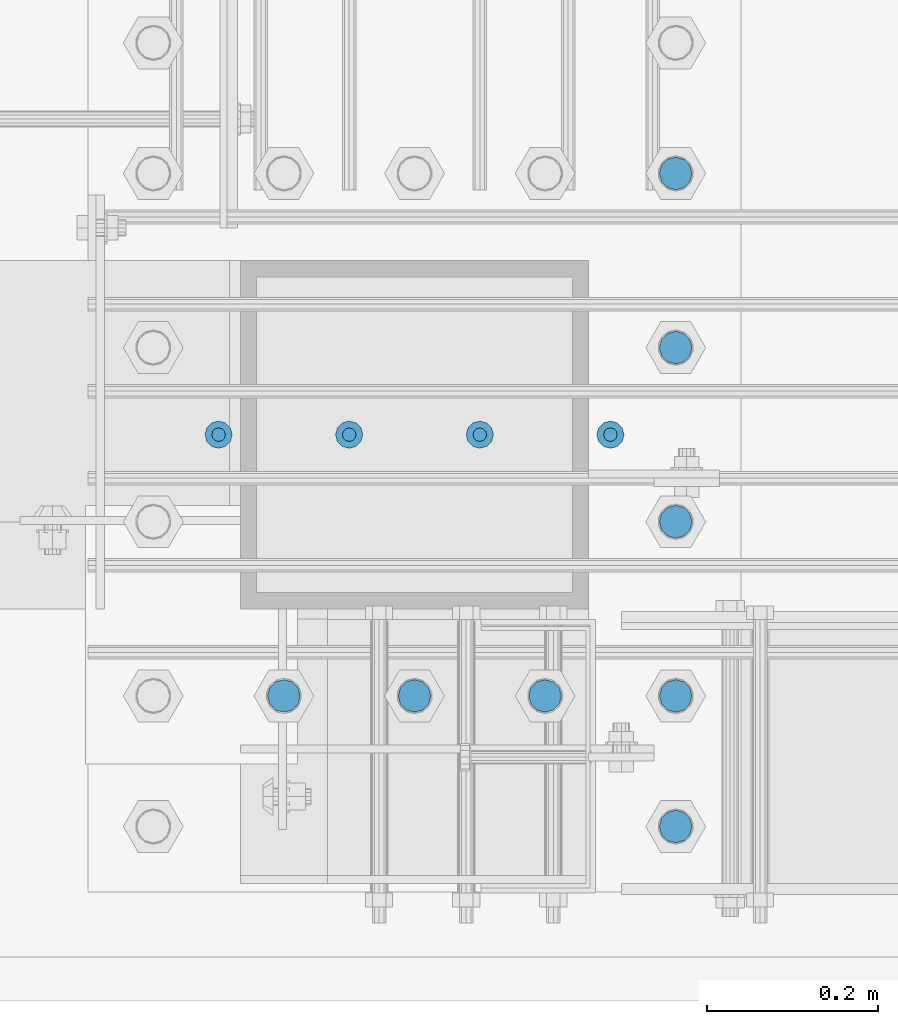
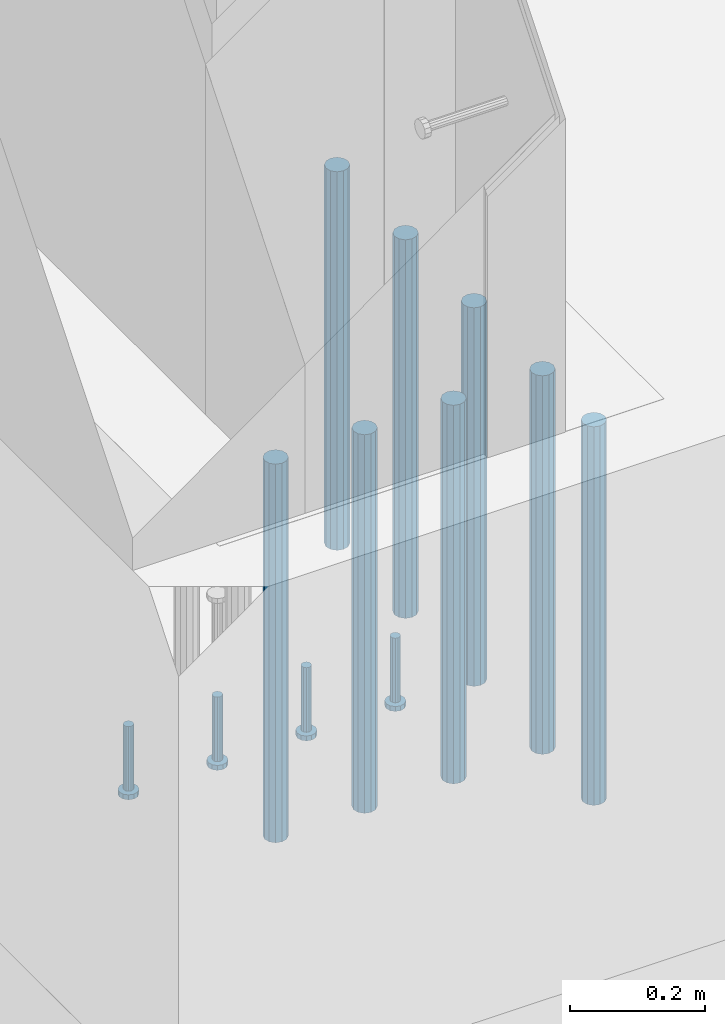
# One storey, part 1082 of 1876: 12 beams, 1 element without a shape of its own.
"""IFC2X3 building model written with IfcOpenShell, lengths in millimetres."""

from ifc_helpers import new_model, si_unit, frame, origin_with_axes, place, context, subcontext, project, spatial, faceted_brep, material, type_object, element, aggregate, save


model = new_model("IFC2X3")

# Units and contexts
model_context = context("Model", 3, precision=1e-05, world=origin_with_axes())
body_context = subcontext(model_context, "Body", "Model", "MODEL_VIEW")
ifc_project = project(units=[si_unit("LENGTHUNIT", "METRE", prefix="MILLI"), si_unit("AREAUNIT", "SQUARE_METRE"), si_unit("VOLUMEUNIT", "CUBIC_METRE"), si_unit("MASSUNIT", "GRAM", prefix="KILO"), si_unit("TIMEUNIT", "SECOND"), si_unit("PLANEANGLEUNIT", "RADIAN"), si_unit("SOLIDANGLEUNIT", "STERADIAN"), si_unit("THERMODYNAMICTEMPERATUREUNIT", "DEGREE_CELSIUS"), si_unit("LUMINOUSINTENSITYUNIT", "LUMEN")], contexts=[model_context])

# Site, building, storey
site_placement = place(None, origin_with_axes())
site = spatial("IfcSite", under=ifc_project, at=site_placement, CompositionType="ELEMENT")
building_placement = place(site_placement, origin_with_axes())
building = spatial("IfcBuilding", under=site, at=building_placement, Name="Undefined", CompositionType="ELEMENT")
storey_placement = place(building_placement, origin_with_axes())
storey = spatial("IfcBuildingStorey", under=building, at=storey_placement, Name="Undefined", CompositionType="ELEMENT", Elevation=0.0)

# Assembly, beams
assembly_placement = place(storey_placement, origin_with_axes())
assembly = element("IfcElementAssembly", 1, at=assembly_placement, inside=storey, Name="PLATE", AssemblyPlace="NOTDEFINED", PredefinedType="RIGID_FRAME")
ifc_material_1 = material(Name="STEEL/F1554-55, S1")
beam_type_1 = type_object("IfcBeamType", PredefinedType="NOTDEFINED")
beam_1_placement = place(assembly_placement, frame((536.574999931718, -25095.2000000075, -57.1499999999993), z_axis=(0.0, -1.0, 0.0), x_axis=(0.0, 0.0, -1.0)))
beam_1 = element("IfcBeam", 2, at=beam_1_placement, type_object=beam_type_1, material=ifc_material_1, Name="WELDED ANCHORS", context=body_context, shape_type="Brep", body=[
    faceted_brep([(0.0, -19.0500000000002, 0.0), (0.0, -16.4977839420935, -9.52500000000146), (685.799999999999, -16.4977839420936, -9.52500000000146), (685.799999999999, -19.05, 0.0), (0.0, -9.52500000000009, -16.4977839420935), (685.799999999999, -9.52499999999998, -16.4977839420935), (0.0, 0.0, -19.05), (685.799999999999, 0.0, -19.0499999999993), (0.0, 9.52500000000009, -16.4977839420935), (685.799999999999, 9.52500000000003, -16.4977839420935), (0.0, 16.4977839420935, -9.52500000000146), (685.799999999999, 16.4977839420936, -9.52500000000146), (-9.09494701772928e-13, 19.05, -1.81898940354586e-12), (685.799999999999, 19.05, 0.0), (0.0, 16.4977839420935, 9.52500000000146), (685.799999999999, 16.4977839420936, 9.52500000000146), (0.0, 9.52500000000009, 16.4977839420935), (685.799999999999, 9.52499999999998, 16.4977839420935), (0.0, 0.0, 19.0499999999993), (685.799999999999, 0.0, 19.0499999999993), (0.0, -9.52500000000009, 16.4977839420935), (685.799999999999, -9.52499999999998, 16.4977839420935), (0.0, -16.4977839420935, 9.52500000000146), (685.799999999999, -16.4977839420936, 9.52500000000146)], [[[0, 1, 2, 3]], [[1, 4, 5, 2]], [[4, 6, 7, 5]], [[6, 8, 9, 7]], [[8, 10, 11, 9]], [[10, 12, 13, 11]], [[12, 14, 15, 13]], [[14, 16, 17, 15]], [[16, 18, 19, 17]], [[18, 20, 21, 19]], [[20, 22, 23, 21]], [[22, 0, 3, 23]], [[5, 7, 9, 11, 13, 15, 17, 19, 21, 23, 3, 2]], [[22, 20, 18, 16, 14, 12, 10, 8, 6, 4, 1, 0]]]),
])
beam_2_placement = place(assembly_placement, frame((536.574999931718, -25298.4000000075, -57.1499999999993), z_axis=(0.0, -1.0, 0.0), x_axis=(0.0, 0.0, -1.0)))
beam_2 = element("IfcBeam", 3, at=beam_2_placement, type_object=beam_type_1, material=ifc_material_1, Name="WELDED ANCHORS", context=body_context, shape_type="Brep", body=[
    faceted_brep([(0.0, -19.0500000000002, 0.0), (0.0, -16.4977839420935, -9.52500000000146), (685.799999999999, -16.4977839420936, -9.52500000000146), (685.799999999999, -19.05, 0.0), (0.0, -9.52500000000009, -16.4977839420935), (685.799999999999, -9.52499999999998, -16.4977839420935), (0.0, 0.0, -19.05), (685.799999999999, 0.0, -19.0499999999993), (0.0, 9.52500000000009, -16.4977839420935), (685.799999999999, 9.52500000000003, -16.4977839420935), (0.0, 16.4977839420935, -9.52500000000146), (685.799999999999, 16.4977839420936, -9.52500000000146), (-9.09494701772928e-13, 19.05, -1.81898940354586e-12), (685.799999999999, 19.05, 0.0), (0.0, 16.4977839420935, 9.52500000000146), (685.799999999999, 16.4977839420936, 9.52500000000146), (0.0, 9.52500000000009, 16.4977839420935), (685.799999999999, 9.52499999999998, 16.4977839420935), (0.0, 0.0, 19.0499999999993), (685.799999999999, 0.0, 19.0499999999993), (0.0, -9.52500000000009, 16.4977839420935), (685.799999999999, -9.52499999999998, 16.4977839420935), (0.0, -16.4977839420935, 9.52500000000146), (685.799999999999, -16.4977839420936, 9.52500000000146)], [[[0, 1, 2, 3]], [[1, 4, 5, 2]], [[4, 6, 7, 5]], [[6, 8, 9, 7]], [[8, 10, 11, 9]], [[10, 12, 13, 11]], [[12, 14, 15, 13]], [[14, 16, 17, 15]], [[16, 18, 19, 17]], [[18, 20, 21, 19]], [[20, 22, 23, 21]], [[22, 0, 3, 23]], [[5, 7, 9, 11, 13, 15, 17, 19, 21, 23, 3, 2]], [[22, 20, 18, 16, 14, 12, 10, 8, 6, 4, 1, 0]]]),
])
beam_3_placement = place(assembly_placement, frame((536.574999931718, -25501.6000000075, -57.1499999999993), z_axis=(0.0, -1.0, 0.0), x_axis=(0.0, 0.0, -1.0)))
beam_3 = element("IfcBeam", 4, at=beam_3_placement, type_object=beam_type_1, material=ifc_material_1, Name="WELDED ANCHORS", context=body_context, shape_type="Brep", body=[
    faceted_brep([(0.0, -19.0500000000002, 0.0), (0.0, -16.4977839420935, -9.52500000000146), (685.799999999999, -16.4977839420936, -9.52500000000146), (685.799999999999, -19.05, 0.0), (0.0, -9.52500000000009, -16.4977839420935), (685.799999999999, -9.52499999999998, -16.4977839420935), (0.0, 0.0, -19.05), (685.799999999999, 0.0, -19.0499999999993), (0.0, 9.52500000000009, -16.4977839420935), (685.799999999999, 9.52500000000003, -16.4977839420935), (0.0, 16.4977839420935, -9.52500000000146), (685.799999999999, 16.4977839420936, -9.52500000000146), (-9.09494701772928e-13, 19.05, -1.81898940354586e-12), (685.799999999999, 19.05, 0.0), (0.0, 16.4977839420935, 9.52500000000146), (685.799999999999, 16.4977839420936, 9.52500000000146), (0.0, 9.52500000000009, 16.4977839420935), (685.799999999999, 9.52499999999998, 16.4977839420935), (0.0, 0.0, 19.0499999999993), (685.799999999999, 0.0, 19.0499999999993), (0.0, -9.52500000000009, 16.4977839420935), (685.799999999999, -9.52499999999998, 16.4977839420935), (0.0, -16.4977839420935, 9.52500000000146), (685.799999999999, -16.4977839420936, 9.52500000000146)], [[[0, 1, 2, 3]], [[1, 4, 5, 2]], [[4, 6, 7, 5]], [[6, 8, 9, 7]], [[8, 10, 11, 9]], [[10, 12, 13, 11]], [[12, 14, 15, 13]], [[14, 16, 17, 15]], [[16, 18, 19, 17]], [[18, 20, 21, 19]], [[20, 22, 23, 21]], [[22, 0, 3, 23]], [[5, 7, 9, 11, 13, 15, 17, 19, 21, 23, 3, 2]], [[22, 20, 18, 16, 14, 12, 10, 8, 6, 4, 1, 0]]]),
])
beam_4_placement = place(assembly_placement, frame((536.574999931718, -25857.2000000075, -57.1499999999993), z_axis=(0.0, -1.0, 0.0), x_axis=(0.0, 0.0, -1.0)))
beam_4 = element("IfcBeam", 5, at=beam_4_placement, type_object=beam_type_1, material=ifc_material_1, Name="WELDED ANCHORS", context=body_context, shape_type="Brep", body=[
    faceted_brep([(0.0, -19.0500000000002, 0.0), (0.0, -16.4977839420935, -9.52500000000146), (685.799999999999, -16.4977839420936, -9.52500000000146), (685.799999999999, -19.05, 0.0), (0.0, -9.52500000000009, -16.4977839420935), (685.799999999999, -9.52499999999998, -16.4977839420935), (0.0, 0.0, -19.05), (685.799999999999, 0.0, -19.0499999999993), (0.0, 9.52500000000009, -16.4977839420935), (685.799999999999, 9.52500000000003, -16.4977839420935), (0.0, 16.4977839420935, -9.52500000000146), (685.799999999999, 16.4977839420936, -9.52500000000146), (-9.09494701772928e-13, 19.05, -1.81898940354586e-12), (685.799999999999, 19.05, 0.0), (0.0, 16.4977839420935, 9.52500000000146), (685.799999999999, 16.4977839420936, 9.52500000000146), (0.0, 9.52500000000009, 16.4977839420935), (685.799999999999, 9.52499999999998, 16.4977839420935), (0.0, 0.0, 19.0499999999993), (685.799999999999, 0.0, 19.0499999999993), (0.0, -9.52500000000009, 16.4977839420935), (685.799999999999, -9.52499999999998, 16.4977839420935), (0.0, -16.4977839420935, 9.52500000000146), (685.799999999999, -16.4977839420936, 9.52500000000146)], [[[0, 1, 2, 3]], [[1, 4, 5, 2]], [[4, 6, 7, 5]], [[6, 8, 9, 7]], [[8, 10, 11, 9]], [[10, 12, 13, 11]], [[12, 14, 15, 13]], [[14, 16, 17, 15]], [[16, 18, 19, 17]], [[18, 20, 21, 19]], [[20, 22, 23, 21]], [[22, 0, 3, 23]], [[5, 7, 9, 11, 13, 15, 17, 19, 21, 23, 3, 2]], [[22, 20, 18, 16, 14, 12, 10, 8, 6, 4, 1, 0]]]),
])
beam_5_placement = place(assembly_placement, frame((384.174998062665, -25704.8000013791, -57.1499999999993), z_axis=(0.0, -1.0, 0.0), x_axis=(0.0, 0.0, -1.0)))
beam_5 = element("IfcBeam", 6, at=beam_5_placement, type_object=beam_type_1, material=ifc_material_1, Name="WELDED ANCHORS", context=body_context, shape_type="Brep", body=[
    faceted_brep([(0.0, -19.0500000000002, 0.0), (0.0, -16.4977839420935, -9.52500000000146), (685.799999999999, -16.4977839420936, -9.52500000000146), (685.799999999999, -19.05, 0.0), (0.0, -9.52500000000009, -16.4977839420935), (685.799999999999, -9.52499999999998, -16.4977839420935), (0.0, 0.0, -19.05), (685.799999999999, 0.0, -19.0499999999993), (0.0, 9.52500000000009, -16.4977839420935), (685.799999999999, 9.52500000000003, -16.4977839420935), (0.0, 16.4977839420935, -9.52500000000146), (685.799999999999, 16.4977839420936, -9.52500000000146), (-9.09494701772928e-13, 19.05, -1.81898940354586e-12), (685.799999999999, 19.05, 0.0), (0.0, 16.4977839420935, 9.52500000000146), (685.799999999999, 16.4977839420936, 9.52500000000146), (0.0, 9.52500000000009, 16.4977839420935), (685.799999999999, 9.52499999999998, 16.4977839420935), (0.0, 0.0, 19.0499999999993), (685.799999999999, 0.0, 19.0499999999993), (0.0, -9.52500000000009, 16.4977839420935), (685.799999999999, -9.52499999999998, 16.4977839420935), (0.0, -16.4977839420935, 9.52500000000146), (685.799999999999, -16.4977839420936, 9.52500000000146)], [[[0, 1, 2, 3]], [[1, 4, 5, 2]], [[4, 6, 7, 5]], [[6, 8, 9, 7]], [[8, 10, 11, 9]], [[10, 12, 13, 11]], [[12, 14, 15, 13]], [[14, 16, 17, 15]], [[16, 18, 19, 17]], [[18, 20, 21, 19]], [[20, 22, 23, 21]], [[22, 0, 3, 23]], [[5, 7, 9, 11, 13, 15, 17, 19, 21, 23, 3, 2]], [[22, 20, 18, 16, 14, 12, 10, 8, 6, 4, 1, 0]]]),
])
beam_6_placement = place(assembly_placement, frame((231.774998062665, -25704.8000027507, -57.1499999999993), z_axis=(0.0, -1.0, 0.0), x_axis=(0.0, 0.0, -1.0)))
beam_6 = element("IfcBeam", 7, at=beam_6_placement, type_object=beam_type_1, material=ifc_material_1, Name="WELDED ANCHORS", context=body_context, shape_type="Brep", body=[
    faceted_brep([(0.0, -19.0500000000002, 0.0), (0.0, -16.4977839420935, -9.52500000000146), (685.799999999999, -16.4977839420936, -9.52500000000146), (685.799999999999, -19.05, 0.0), (0.0, -9.52500000000009, -16.4977839420935), (685.799999999999, -9.52499999999998, -16.4977839420935), (0.0, 0.0, -19.05), (685.799999999999, 0.0, -19.0499999999993), (0.0, 9.52500000000009, -16.4977839420935), (685.799999999999, 9.52500000000003, -16.4977839420935), (0.0, 16.4977839420935, -9.52500000000146), (685.799999999999, 16.4977839420936, -9.52500000000146), (-9.09494701772928e-13, 19.05, -1.81898940354586e-12), (685.799999999999, 19.05, 0.0), (0.0, 16.4977839420935, 9.52500000000146), (685.799999999999, 16.4977839420936, 9.52500000000146), (0.0, 9.52500000000009, 16.4977839420935), (685.799999999999, 9.52499999999998, 16.4977839420935), (0.0, 0.0, 19.0499999999993), (685.799999999999, 0.0, 19.0499999999993), (0.0, -9.52500000000009, 16.4977839420935), (685.799999999999, -9.52499999999998, 16.4977839420935), (0.0, -16.4977839420935, 9.52500000000146), (685.799999999999, -16.4977839420936, 9.52500000000146)], [[[0, 1, 2, 3]], [[1, 4, 5, 2]], [[4, 6, 7, 5]], [[6, 8, 9, 7]], [[8, 10, 11, 9]], [[10, 12, 13, 11]], [[12, 14, 15, 13]], [[14, 16, 17, 15]], [[16, 18, 19, 17]], [[18, 20, 21, 19]], [[20, 22, 23, 21]], [[22, 0, 3, 23]], [[5, 7, 9, 11, 13, 15, 17, 19, 21, 23, 3, 2]], [[22, 20, 18, 16, 14, 12, 10, 8, 6, 4, 1, 0]]]),
])
beam_7_placement = place(assembly_placement, frame((79.3749980626652, -25704.8000041223, -57.1499999999993), z_axis=(0.0, -1.0, 0.0), x_axis=(0.0, 0.0, -1.0)))
beam_7 = element("IfcBeam", 8, at=beam_7_placement, type_object=beam_type_1, material=ifc_material_1, Name="WELDED ANCHORS", context=body_context, shape_type="Brep", body=[
    faceted_brep([(0.0, -19.0500000000002, 0.0), (0.0, -16.4977839420935, -9.52500000000146), (685.799999999999, -16.4977839420936, -9.52500000000146), (685.799999999999, -19.05, 0.0), (0.0, -9.52500000000009, -16.4977839420935), (685.799999999999, -9.52499999999998, -16.4977839420935), (0.0, 0.0, -19.05), (685.799999999999, 0.0, -19.0499999999993), (0.0, 9.52500000000009, -16.4977839420935), (685.799999999999, 9.52500000000003, -16.4977839420935), (0.0, 16.4977839420935, -9.52500000000146), (685.799999999999, 16.4977839420936, -9.52500000000146), (-9.09494701772928e-13, 19.05, -1.81898940354586e-12), (685.799999999999, 19.05, 0.0), (0.0, 16.4977839420935, 9.52500000000146), (685.799999999999, 16.4977839420936, 9.52500000000146), (0.0, 9.52500000000009, 16.4977839420935), (685.799999999999, 9.52499999999998, 16.4977839420935), (0.0, 0.0, 19.0499999999993), (685.799999999999, 0.0, 19.0499999999993), (0.0, -9.52500000000009, 16.4977839420935), (685.799999999999, -9.52499999999998, 16.4977839420935), (0.0, -16.4977839420935, 9.52500000000146), (685.799999999999, -16.4977839420936, 9.52500000000146)], [[[0, 1, 2, 3]], [[1, 4, 5, 2]], [[4, 6, 7, 5]], [[6, 8, 9, 7]], [[8, 10, 11, 9]], [[10, 12, 13, 11]], [[12, 14, 15, 13]], [[14, 16, 17, 15]], [[16, 18, 19, 17]], [[18, 20, 21, 19]], [[20, 22, 23, 21]], [[22, 0, 3, 23]], [[5, 7, 9, 11, 13, 15, 17, 19, 21, 23, 3, 2]], [[22, 20, 18, 16, 14, 12, 10, 8, 6, 4, 1, 0]]]),
])
beam_8_placement = place(assembly_placement, frame((536.574999931718, -25704.8000000075, -57.1499999999993), z_axis=(0.0, -1.0, 0.0), x_axis=(0.0, 0.0, -1.0)))
beam_8 = element("IfcBeam", 9, at=beam_8_placement, type_object=beam_type_1, material=ifc_material_1, Name="WELDED ANCHORS", context=body_context, shape_type="Brep", body=[
    faceted_brep([(0.0, -19.0500000000002, 0.0), (0.0, -16.4977839420935, -9.52500000000146), (685.799999999999, -16.4977839420936, -9.52500000000146), (685.799999999999, -19.05, 0.0), (0.0, -9.52500000000009, -16.4977839420935), (685.799999999999, -9.52499999999998, -16.4977839420935), (0.0, 0.0, -19.05), (685.799999999999, 0.0, -19.0499999999993), (0.0, 9.52500000000009, -16.4977839420935), (685.799999999999, 9.52500000000003, -16.4977839420935), (0.0, 16.4977839420935, -9.52500000000146), (685.799999999999, 16.4977839420936, -9.52500000000146), (-9.09494701772928e-13, 19.05, -1.81898940354586e-12), (685.799999999999, 19.05, 0.0), (0.0, 16.4977839420935, 9.52500000000146), (685.799999999999, 16.4977839420936, 9.52500000000146), (0.0, 9.52500000000009, 16.4977839420935), (685.799999999999, 9.52499999999998, 16.4977839420935), (0.0, 0.0, 19.0499999999993), (685.799999999999, 0.0, 19.0499999999993), (0.0, -9.52500000000009, 16.4977839420935), (685.799999999999, -9.52499999999998, 16.4977839420935), (0.0, -16.4977839420935, 9.52500000000146), (685.799999999999, -16.4977839420936, 9.52500000000146)], [[[0, 1, 2, 3]], [[1, 4, 5, 2]], [[4, 6, 7, 5]], [[6, 8, 9, 7]], [[8, 10, 11, 9]], [[10, 12, 13, 11]], [[12, 14, 15, 13]], [[14, 16, 17, 15]], [[16, 18, 19, 17]], [[18, 20, 21, 19]], [[20, 22, 23, 21]], [[22, 0, 3, 23]], [[5, 7, 9, 11, 13, 15, 17, 19, 21, 23, 3, 2]], [[22, 20, 18, 16, 14, 12, 10, 8, 6, 4, 1, 0]]]),
])
ifc_material_2 = material(Name="STEEL/A108")
beam_type_2 = type_object("IfcBeamType", Name="5/8-DIA_HEADED ANCHOR STUD", PredefinedType="NOTDEFINED")
beam_9_placement = place(assembly_placement, frame((460.375009117128, -25400.0, -698.499999999996), z_axis=(1.0, 0.0, 0.0), x_axis=(0.0, 0.0, -1.0)))
beam_9 = element("IfcBeam", 10, at=beam_9_placement, type_object=beam_type_2, material=ifc_material_2, Name="HEADED ANCHOR STUD", ObjectType="5/8-DIA_HEADED ANCHOR STUD", context=body_context, shape_type="Brep", body=[
    faceted_brep([(0.0, -7.94000005722046, 0.0), (0.0, -6.86999988555908, -3.97000002861023), (116.84, -6.86999988555908, -3.97000002861023), (116.84, -7.94000005722046, 0.0), (0.0, -3.97000002861023, -6.86999988555908), (116.84, -3.97000002861023, -6.86999988555908), (0.0, 0.0, -7.94000005722046), (116.84, 0.0, -7.94000005722046), (0.0, 3.97000002861023, -6.86999988555908), (116.84, 3.97000002861023, -6.86999988555908), (0.0, 6.86999988555908, -3.97000002861023), (116.84, 6.86999988555908, -3.97000002861023), (0.0, 7.94000005722046, 0.0), (116.84, 7.94000005722046, 0.0), (0.0, 6.86999988555908, 3.97000002861023), (116.84, 6.86999988555908, 3.97000002861023), (0.0, 3.97000002861023, 6.86999988555908), (116.84, 3.97000002861023, 6.86999988555908), (0.0, 0.0, 7.94000005722046), (116.84, 0.0, 7.94000005722046), (0.0, -3.97000002861023, 6.86999988555908), (116.84, -3.97000002861023, 6.86999988555908), (0.0, -6.86999988555908, 3.97000002861023), (116.84, -6.86999988555908, 3.97000002861023), (118.11, -13.75, -7.94000005722046), (118.11, -15.8800001144409, 0.0), (118.11, -7.94000005722046, -13.75), (118.11, 0.0, -15.8800001144409), (118.11, 7.94000005722046, -13.75), (118.11, 13.75, -7.94000005722046), (118.11, 15.8800001144409, 0.0), (118.11, 13.75, 7.94000005722046), (118.11, 7.94000005722046, 13.75), (118.11, 0.0, 15.8800001144409), (118.11, -7.94000005722046, 13.75), (118.11, -13.75, 7.94000005722046), (127.0, -13.75, -7.94000005722046), (127.0, -15.8800001144409, 0.0), (127.0, -7.94000005722046, -13.75), (127.0, 0.0, -15.8800001144409), (127.0, 7.94000005722046, -13.75), (127.0, 13.75, -7.94000005722046), (127.0, 15.8800001144409, 0.0), (127.0, 13.75, 7.94000005722046), (127.0, 7.94000005722046, 13.75), (127.0, 0.0, 15.8800001144409), (127.0, -7.94000005722046, 13.75), (127.0, -13.75, 7.94000005722046)], [[[0, 1, 2, 3]], [[1, 4, 5, 2]], [[4, 6, 7, 5]], [[6, 8, 9, 7]], [[8, 10, 11, 9]], [[10, 12, 13, 11]], [[12, 14, 15, 13]], [[14, 16, 17, 15]], [[16, 18, 19, 17]], [[18, 20, 21, 19]], [[20, 22, 23, 21]], [[22, 0, 3, 23]], [[22, 20, 18, 16, 14, 12, 10, 8, 6, 4, 1, 0]], [[3, 2, 24, 25]], [[2, 5, 26, 24]], [[5, 7, 27, 26]], [[7, 9, 28, 27]], [[9, 11, 29, 28]], [[11, 13, 30, 29]], [[13, 15, 31, 30]], [[15, 17, 32, 31]], [[17, 19, 33, 32]], [[19, 21, 34, 33]], [[21, 23, 35, 34]], [[23, 3, 25, 35]], [[25, 24, 36, 37]], [[24, 26, 38, 36]], [[26, 27, 39, 38]], [[27, 28, 40, 39]], [[28, 29, 41, 40]], [[29, 30, 42, 41]], [[30, 31, 43, 42]], [[31, 32, 44, 43]], [[32, 33, 45, 44]], [[33, 34, 46, 45]], [[34, 35, 47, 46]], [[35, 25, 37, 47]], [[38, 39, 40, 41, 42, 43, 44, 45, 46, 47, 37, 36]]]),
])
beam_10_placement = place(assembly_placement, frame((307.974987792966, -25400.0, -698.499999999996), z_axis=(1.0, 0.0, 0.0), x_axis=(0.0, 0.0, -1.0)))
beam_10 = element("IfcBeam", 11, at=beam_10_placement, type_object=beam_type_2, material=ifc_material_2, Name="HEADED ANCHOR STUD", ObjectType="5/8-DIA_HEADED ANCHOR STUD", context=body_context, shape_type="Brep", body=[
    faceted_brep([(0.0, -7.94000005722046, 0.0), (0.0, -6.86999988555908, -3.97000002861023), (116.84, -6.86999988555908, -3.97000002861023), (116.84, -7.94000005722046, 0.0), (0.0, -3.97000002861023, -6.86999988555908), (116.84, -3.97000002861023, -6.86999988555908), (0.0, 0.0, -7.94000005722046), (116.84, 0.0, -7.94000005722046), (0.0, 3.97000002861023, -6.86999988555908), (116.84, 3.97000002861023, -6.86999988555908), (0.0, 6.86999988555908, -3.97000002861023), (116.84, 6.86999988555908, -3.97000002861023), (0.0, 7.94000005722046, 0.0), (116.84, 7.94000005722046, 0.0), (0.0, 6.86999988555908, 3.97000002861023), (116.84, 6.86999988555908, 3.97000002861023), (0.0, 3.97000002861023, 6.86999988555908), (116.84, 3.97000002861023, 6.86999988555908), (0.0, 0.0, 7.94000005722046), (116.84, 0.0, 7.94000005722046), (0.0, -3.97000002861023, 6.86999988555908), (116.84, -3.97000002861023, 6.86999988555908), (0.0, -6.86999988555908, 3.97000002861023), (116.84, -6.86999988555908, 3.97000002861023), (118.11, -13.75, -7.94000005722046), (118.11, -15.8800001144409, 0.0), (118.11, -7.94000005722046, -13.75), (118.11, 0.0, -15.8800001144409), (118.11, 7.94000005722046, -13.75), (118.11, 13.75, -7.94000005722046), (118.11, 15.8800001144409, 0.0), (118.11, 13.75, 7.94000005722046), (118.11, 7.94000005722046, 13.75), (118.11, 0.0, 15.8800001144409), (118.11, -7.94000005722046, 13.75), (118.11, -13.75, 7.94000005722046), (127.0, -13.75, -7.94000005722046), (127.0, -15.8800001144409, 0.0), (127.0, -7.94000005722046, -13.75), (127.0, 0.0, -15.8800001144409), (127.0, 7.94000005722046, -13.75), (127.0, 13.75, -7.94000005722046), (127.0, 15.8800001144409, 0.0), (127.0, 13.75, 7.94000005722046), (127.0, 7.94000005722046, 13.75), (127.0, 0.0, 15.8800001144409), (127.0, -7.94000005722046, 13.75), (127.0, -13.75, 7.94000005722046)], [[[0, 1, 2, 3]], [[1, 4, 5, 2]], [[4, 6, 7, 5]], [[6, 8, 9, 7]], [[8, 10, 11, 9]], [[10, 12, 13, 11]], [[12, 14, 15, 13]], [[14, 16, 17, 15]], [[16, 18, 19, 17]], [[18, 20, 21, 19]], [[20, 22, 23, 21]], [[22, 0, 3, 23]], [[22, 20, 18, 16, 14, 12, 10, 8, 6, 4, 1, 0]], [[3, 2, 24, 25]], [[2, 5, 26, 24]], [[5, 7, 27, 26]], [[7, 9, 28, 27]], [[9, 11, 29, 28]], [[11, 13, 30, 29]], [[13, 15, 31, 30]], [[15, 17, 32, 31]], [[17, 19, 33, 32]], [[19, 21, 34, 33]], [[21, 23, 35, 34]], [[23, 3, 25, 35]], [[25, 24, 36, 37]], [[24, 26, 38, 36]], [[26, 27, 39, 38]], [[27, 28, 40, 39]], [[28, 29, 41, 40]], [[29, 30, 42, 41]], [[30, 31, 43, 42]], [[31, 32, 44, 43]], [[32, 33, 45, 44]], [[33, 34, 46, 45]], [[34, 35, 47, 46]], [[35, 25, 37, 47]], [[38, 39, 40, 41, 42, 43, 44, 45, 46, 47, 37, 36]]]),
])
beam_11_placement = place(assembly_placement, frame((155.57500606537, -25399.9999509433, -698.499999999996), z_axis=(1.0, 0.0, 0.0), x_axis=(0.0, 0.0, -1.0)))
beam_11 = element("IfcBeam", 12, at=beam_11_placement, type_object=beam_type_2, material=ifc_material_2, Name="HEADED ANCHOR STUD", ObjectType="5/8-DIA_HEADED ANCHOR STUD", context=body_context, shape_type="Brep", body=[
    faceted_brep([(0.0, -7.94000005722046, 0.0), (0.0, -6.86999988555908, -3.97000002861023), (116.84, -6.86999988555908, -3.97000002861023), (116.84, -7.94000005722046, 0.0), (0.0, -3.97000002861023, -6.86999988555908), (116.84, -3.97000002861023, -6.86999988555908), (0.0, 0.0, -7.94000005722046), (116.84, 0.0, -7.94000005722046), (0.0, 3.97000002861023, -6.86999988555908), (116.84, 3.97000002861023, -6.86999988555908), (0.0, 6.86999988555908, -3.97000002861023), (116.84, 6.86999988555908, -3.97000002861023), (0.0, 7.94000005722046, 0.0), (116.84, 7.94000005722046, 0.0), (0.0, 6.86999988555908, 3.97000002861023), (116.84, 6.86999988555908, 3.97000002861023), (0.0, 3.97000002861023, 6.86999988555908), (116.84, 3.97000002861023, 6.86999988555908), (0.0, 0.0, 7.94000005722046), (116.84, 0.0, 7.94000005722046), (0.0, -3.97000002861023, 6.86999988555908), (116.84, -3.97000002861023, 6.86999988555908), (0.0, -6.86999988555908, 3.97000002861023), (116.84, -6.86999988555908, 3.97000002861023), (118.11, -13.75, -7.94000005722046), (118.11, -15.8800001144409, 0.0), (118.11, -7.94000005722046, -13.75), (118.11, 0.0, -15.8800001144409), (118.11, 7.94000005722046, -13.75), (118.11, 13.75, -7.94000005722046), (118.11, 15.8800001144409, 0.0), (118.11, 13.75, 7.94000005722046), (118.11, 7.94000005722046, 13.75), (118.11, 0.0, 15.8800001144409), (118.11, -7.94000005722046, 13.75), (118.11, -13.75, 7.94000005722046), (127.0, -13.75, -7.94000005722046), (127.0, -15.8800001144409, 0.0), (127.0, -7.94000005722046, -13.75), (127.0, 0.0, -15.8800001144409), (127.0, 7.94000005722046, -13.75), (127.0, 13.75, -7.94000005722046), (127.0, 15.8800001144409, 0.0), (127.0, 13.75, 7.94000005722046), (127.0, 7.94000005722046, 13.75), (127.0, 0.0, 15.8800001144409), (127.0, -7.94000005722046, 13.75), (127.0, -13.75, 7.94000005722046)], [[[0, 1, 2, 3]], [[1, 4, 5, 2]], [[4, 6, 7, 5]], [[6, 8, 9, 7]], [[8, 10, 11, 9]], [[10, 12, 13, 11]], [[12, 14, 15, 13]], [[14, 16, 17, 15]], [[16, 18, 19, 17]], [[18, 20, 21, 19]], [[20, 22, 23, 21]], [[22, 0, 3, 23]], [[22, 20, 18, 16, 14, 12, 10, 8, 6, 4, 1, 0]], [[3, 2, 24, 25]], [[2, 5, 26, 24]], [[5, 7, 27, 26]], [[7, 9, 28, 27]], [[9, 11, 29, 28]], [[11, 13, 30, 29]], [[13, 15, 31, 30]], [[15, 17, 32, 31]], [[17, 19, 33, 32]], [[19, 21, 34, 33]], [[21, 23, 35, 34]], [[23, 3, 25, 35]], [[25, 24, 36, 37]], [[24, 26, 38, 36]], [[26, 27, 39, 38]], [[27, 28, 40, 39]], [[28, 29, 41, 40]], [[29, 30, 42, 41]], [[30, 31, 43, 42]], [[31, 32, 44, 43]], [[32, 33, 45, 44]], [[33, 34, 46, 45]], [[34, 35, 47, 46]], [[35, 25, 37, 47]], [[38, 39, 40, 41, 42, 43, 44, 45, 46, 47, 37, 36]]]),
])
beam_12_placement = place(assembly_placement, frame((3.17500607288536, -25399.9999509433, -698.499999999996), z_axis=(1.0, 0.0, 0.0), x_axis=(0.0, 0.0, -1.0)))
beam_12 = element("IfcBeam", 13, at=beam_12_placement, type_object=beam_type_2, material=ifc_material_2, Name="HEADED ANCHOR STUD", ObjectType="5/8-DIA_HEADED ANCHOR STUD", context=body_context, shape_type="Brep", body=[
    faceted_brep([(0.0, -7.94000005722046, 0.0), (0.0, -6.86999988555908, -3.97000002861023), (116.84, -6.86999988555908, -3.97000002861023), (116.84, -7.94000005722046, 0.0), (0.0, -3.97000002861023, -6.86999988555908), (116.84, -3.97000002861023, -6.86999988555908), (0.0, 0.0, -7.94000005722046), (116.84, 0.0, -7.94000005722046), (0.0, 3.97000002861023, -6.86999988555908), (116.84, 3.97000002861023, -6.86999988555908), (0.0, 6.86999988555908, -3.97000002861023), (116.84, 6.86999988555908, -3.97000002861023), (0.0, 7.94000005722046, 0.0), (116.84, 7.94000005722046, 0.0), (0.0, 6.86999988555908, 3.97000002861023), (116.84, 6.86999988555908, 3.97000002861023), (0.0, 3.97000002861023, 6.86999988555908), (116.84, 3.97000002861023, 6.86999988555908), (0.0, 0.0, 7.94000005722046), (116.84, 0.0, 7.94000005722046), (0.0, -3.97000002861023, 6.86999988555908), (116.84, -3.97000002861023, 6.86999988555908), (0.0, -6.86999988555908, 3.97000002861023), (116.84, -6.86999988555908, 3.97000002861023), (118.11, -13.75, -7.94000005722046), (118.11, -15.8800001144409, 0.0), (118.11, -7.94000005722046, -13.75), (118.11, 0.0, -15.8800001144409), (118.11, 7.94000005722046, -13.75), (118.11, 13.75, -7.94000005722046), (118.11, 15.8800001144409, 0.0), (118.11, 13.75, 7.94000005722046), (118.11, 7.94000005722046, 13.75), (118.11, 0.0, 15.8800001144409), (118.11, -7.94000005722046, 13.75), (118.11, -13.75, 7.94000005722046), (127.0, -13.75, -7.94000005722046), (127.0, -15.8800001144409, 0.0), (127.0, -7.94000005722046, -13.75), (127.0, 0.0, -15.8800001144409), (127.0, 7.94000005722046, -13.75), (127.0, 13.75, -7.94000005722046), (127.0, 15.8800001144409, 0.0), (127.0, 13.75, 7.94000005722046), (127.0, 7.94000005722046, 13.75), (127.0, 0.0, 15.8800001144409), (127.0, -7.94000005722046, 13.75), (127.0, -13.75, 7.94000005722046)], [[[0, 1, 2, 3]], [[1, 4, 5, 2]], [[4, 6, 7, 5]], [[6, 8, 9, 7]], [[8, 10, 11, 9]], [[10, 12, 13, 11]], [[12, 14, 15, 13]], [[14, 16, 17, 15]], [[16, 18, 19, 17]], [[18, 20, 21, 19]], [[20, 22, 23, 21]], [[22, 0, 3, 23]], [[22, 20, 18, 16, 14, 12, 10, 8, 6, 4, 1, 0]], [[3, 2, 24, 25]], [[2, 5, 26, 24]], [[5, 7, 27, 26]], [[7, 9, 28, 27]], [[9, 11, 29, 28]], [[11, 13, 30, 29]], [[13, 15, 31, 30]], [[15, 17, 32, 31]], [[17, 19, 33, 32]], [[19, 21, 34, 33]], [[21, 23, 35, 34]], [[23, 3, 25, 35]], [[25, 24, 36, 37]], [[24, 26, 38, 36]], [[26, 27, 39, 38]], [[27, 28, 40, 39]], [[28, 29, 41, 40]], [[29, 30, 42, 41]], [[30, 31, 43, 42]], [[31, 32, 44, 43]], [[32, 33, 45, 44]], [[33, 34, 46, 45]], [[34, 35, 47, 46]], [[35, 25, 37, 47]], [[38, 39, 40, 41, 42, 43, 44, 45, 46, 47, 37, 36]]]),
])
aggregate(assembly, [beam_1, beam_2, beam_3, beam_4, beam_9, beam_10, beam_11, beam_12, beam_5, beam_6, beam_7, beam_8])

save(model, "model.ifc")
